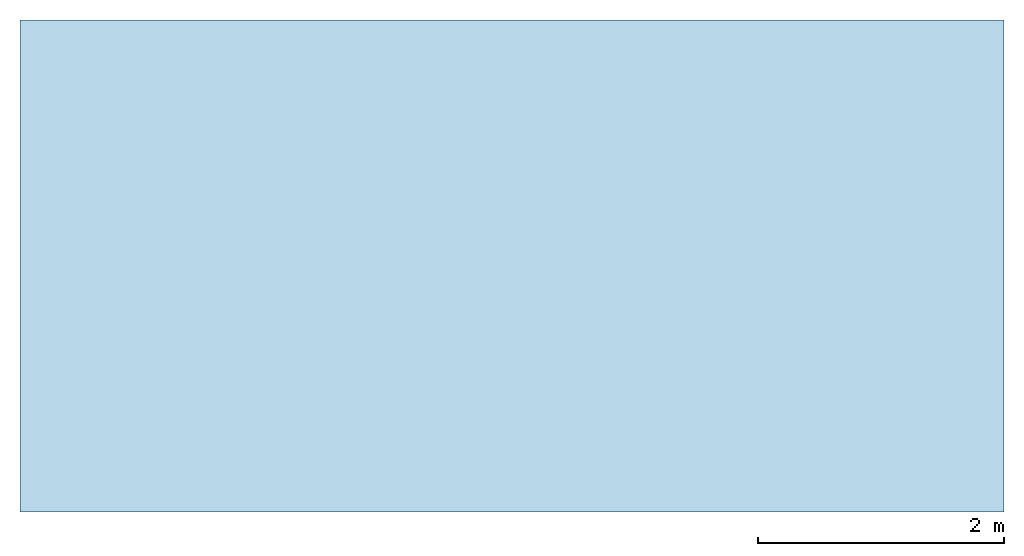
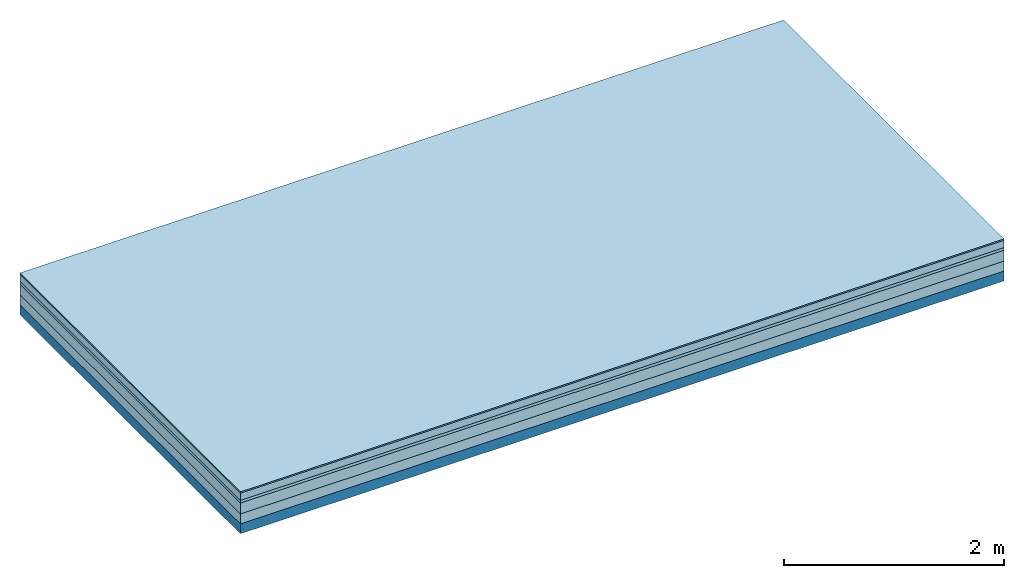
# One storey: 5 plates, 1 member, 1 element without a shape of its own.
"""IFC4 building model written with IfcOpenShell, lengths in metres."""

from ifc_helpers import new_model, si_unit, derived_unit, direction, frame, frame_2d, origin, origin_with_axes, place, context, project, spatial, rectangle, extrude, material, layer, layer_set, type_object, element, aggregate, save


model = new_model("IFC4")

# Units and contexts
plan_context = context("Plan", 3, precision=1e-05, world=origin(), true_north=direction((0.0, 1.0)))
model_context = context("Model", 3, precision=1e-05, world=origin(), true_north=direction((0.0, 1.0)))
ifc_project = project(units=[si_unit("LENGTHUNIT", "METRE"), derived_unit("SOUNDPRESSUREUNIT", [(si_unit("PRESSUREUNIT", "PASCAL", prefix="MICRO"), 0)]), si_unit("ENERGYUNIT", "JOULE", prefix="MEGA"), si_unit("MASSUNIT", "GRAM", prefix="KILO"), derived_unit("THERMALTRANSMITTANCEUNIT", [(si_unit("POWERUNIT", "WATT"), 1), (si_unit("AREAUNIT", "SQUARE_METRE"), -1), (si_unit("THERMODYNAMICTEMPERATUREUNIT", "KELVIN"), -1)]), derived_unit("AREADENSITYUNIT", [(si_unit("MASSUNIT", "GRAM", prefix="KILO"), 1), (si_unit("AREAUNIT", "SQUARE_METRE"), -1)]), derived_unit("USERDEFINED", [(si_unit("ENERGYUNIT", "JOULE", prefix="MEGA"), 1), (si_unit("AREAUNIT", "SQUARE_METRE"), -1)])], contexts=[plan_context, model_context])

# Site, building, storey
site = spatial("IfcSite", under=ifc_project)
building_placement = place(None, origin())
building = spatial("IfcBuilding", under=site, at=building_placement)
storey_placement = place(building_placement, origin())
storey = spatial("IfcBuildingStorey", under=building, at=storey_placement)

# Slab, member, plates
ifc_material_1 = material(Category="11.013")
ifc_layer_1 = layer(ifc_material_1, 0.015, Name="Flooring")
ifc_material_2 = material(Name="Cement screed", Category="04.006")
ifc_layer_2 = layer(ifc_material_2, 0.08, Name="On-material")
ifc_material_3 = material(Name="Wood fiber generic product", Category="10.009")
ifc_layer_3 = layer(ifc_material_3, 0.03, Name="Impact sound insulation")
ifc_material_4 = material(Name="Cement screed with EPS", Category="04.006")
ifc_layer_4 = layer(ifc_material_4, 0.12, Name="on Supporting structure")
ifc_material_5 = material(Category="01.002")
ifc_layer_5 = layer(ifc_material_5, 0.11, Name="Sub-floor")
ifc_material_6 = material(Name="Rigid, of the art")
ifc_layer_6 = layer(ifc_material_6, 0.0, Name="Bond")
ifc_layer_7 = layer(None, 0.11, Name="Supporting structure")
ifc_layer_set = layer_set([ifc_layer_1, ifc_layer_2, ifc_layer_3, ifc_layer_4, ifc_layer_5, ifc_layer_6, ifc_layer_7])
slab_type = type_object("IfcSlabType", Name="A2217", PredefinedType="NOTDEFINED", material=ifc_layer_set)
slab_placement = place(None, frame((0.0, 0.0, 0.0), z_axis=(0.0, 0.0, -1.0), x_axis=(1.0, 0.0, 0.0)))
slab = element("IfcSlab", 1, at=slab_placement, inside=storey, type_object=slab_type, material=ifc_layer_set, Name="Slab #1")
ifc_material_7 = material(Name="Solid timber panel")
member_placement = place(slab_placement, origin())
member = element("IfcMember", 2, at=member_placement, material=ifc_material_7, Name="Supporting structure", context=plan_context, shape_type="SweptSolid", body=[
    extrude(rectangle(XDim=1.0, YDim=0.11, at=frame_2d((0.5, 0.055), x_axis=(1.0, 0.0))), frame((0.0, 4.0, 0.355), z_axis=(0.0, -1.0, 0.0), x_axis=(1.0, 0.0, 0.0)), (0.0, 0.0, 1.0), 4.0),
    extrude(rectangle(XDim=1.0, YDim=0.11, at=frame_2d((0.5, 0.055), x_axis=(1.0, 0.0))), frame((1.0, 4.0, 0.355), z_axis=(0.0, -1.0, 0.0), x_axis=(1.0, 0.0, 0.0)), (0.0, 0.0, 1.0), 4.0),
    extrude(rectangle(XDim=1.0, YDim=0.11, at=frame_2d((0.5, 0.055), x_axis=(1.0, 0.0))), frame((2.0, 4.0, 0.355), z_axis=(0.0, -1.0, 0.0), x_axis=(1.0, 0.0, 0.0)), (0.0, 0.0, 1.0), 4.0),
    extrude(rectangle(XDim=1.0, YDim=0.11, at=frame_2d((0.5, 0.055), x_axis=(1.0, 0.0))), frame((3.0, 4.0, 0.355), z_axis=(0.0, -1.0, 0.0), x_axis=(1.0, 0.0, 0.0)), (0.0, 0.0, 1.0), 4.0),
    extrude(rectangle(XDim=1.0, YDim=0.11, at=frame_2d((0.5, 0.055), x_axis=(1.0, 0.0))), frame((4.0, 4.0, 0.355), z_axis=(0.0, -1.0, 0.0), x_axis=(1.0, 0.0, 0.0)), (0.0, 0.0, 1.0), 4.0),
    extrude(rectangle(XDim=1.0, YDim=0.11, at=frame_2d((0.5, 0.055), x_axis=(1.0, 0.0))), frame((5.0, 4.0, 0.355), z_axis=(0.0, -1.0, 0.0), x_axis=(1.0, 0.0, 0.0)), (0.0, 0.0, 1.0), 4.0),
    extrude(rectangle(XDim=1.0, YDim=0.11, at=frame_2d((0.5, 0.055), x_axis=(1.0, 0.0))), frame((6.0, 4.0, 0.355), z_axis=(0.0, -1.0, 0.0), x_axis=(1.0, 0.0, 0.0)), (0.0, 0.0, 1.0), 4.0),
    extrude(rectangle(XDim=1.0, YDim=0.11, at=frame_2d((0.5, 0.055), x_axis=(1.0, 0.0))), frame((7.0, 4.0, 0.355), z_axis=(0.0, -1.0, 0.0), x_axis=(1.0, 0.0, 0.0)), (0.0, 0.0, 1.0), 4.0),
])
plate_1_placement = place(slab_placement, origin())
plate_1 = element("IfcPlate", 3, at=plate_1_placement, material=ifc_material_1, Name="Flooring", context=plan_context, shape_type="SweptSolid", body=[
    extrude(rectangle(XDim=8.0, YDim=4.0, at=frame_2d((4.0, 2.0), x_axis=(1.0, 0.0))), origin_with_axes(), (0.0, 0.0, 1.0), 0.015),
])
plate_2_placement = place(slab_placement, origin())
plate_2 = element("IfcPlate", 4, at=plate_2_placement, material=ifc_material_2, Name="On-material", context=plan_context, shape_type="SweptSolid", body=[
    extrude(rectangle(XDim=8.0, YDim=4.0, at=frame_2d((4.0, 2.0), x_axis=(1.0, 0.0))), frame((0.0, 0.0, 0.015), z_axis=(0.0, 0.0, 1.0), x_axis=(1.0, 0.0, 0.0)), (0.0, 0.0, 1.0), 0.08),
])
plate_3_placement = place(slab_placement, origin())
plate_3 = element("IfcPlate", 5, at=plate_3_placement, material=ifc_material_3, Name="Impact sound insulation", context=plan_context, shape_type="SweptSolid", body=[
    extrude(rectangle(XDim=8.0, YDim=4.0, at=frame_2d((4.0, 2.0), x_axis=(1.0, 0.0))), frame((0.0, 0.0, 0.095), z_axis=(0.0, 0.0, 1.0), x_axis=(1.0, 0.0, 0.0)), (0.0, 0.0, 1.0), 0.03),
])
plate_4_placement = place(slab_placement, origin())
plate_4 = element("IfcPlate", 6, at=plate_4_placement, material=ifc_material_4, Name="on Supporting structure", context=plan_context, shape_type="SweptSolid", body=[
    extrude(rectangle(XDim=8.0, YDim=4.0, at=frame_2d((4.0, 2.0), x_axis=(1.0, 0.0))), frame((0.0, 0.0, 0.125), z_axis=(0.0, 0.0, 1.0), x_axis=(1.0, 0.0, 0.0)), (0.0, 0.0, 1.0), 0.12),
])
plate_5_placement = place(slab_placement, origin())
plate_5 = element("IfcPlate", 7, at=plate_5_placement, material=ifc_material_5, Name="Sub-floor", context=plan_context, shape_type="SweptSolid", body=[
    extrude(rectangle(XDim=8.0, YDim=4.0, at=frame_2d((4.0, 2.0), x_axis=(1.0, 0.0))), frame((0.0, 0.0, 0.245), z_axis=(0.0, 0.0, 1.0), x_axis=(1.0, 0.0, 0.0)), (0.0, 0.0, 1.0), 0.11),
])
aggregate(slab, [plate_1, plate_2, plate_3, plate_4, plate_5, member])

save(model, "model.ifc")
